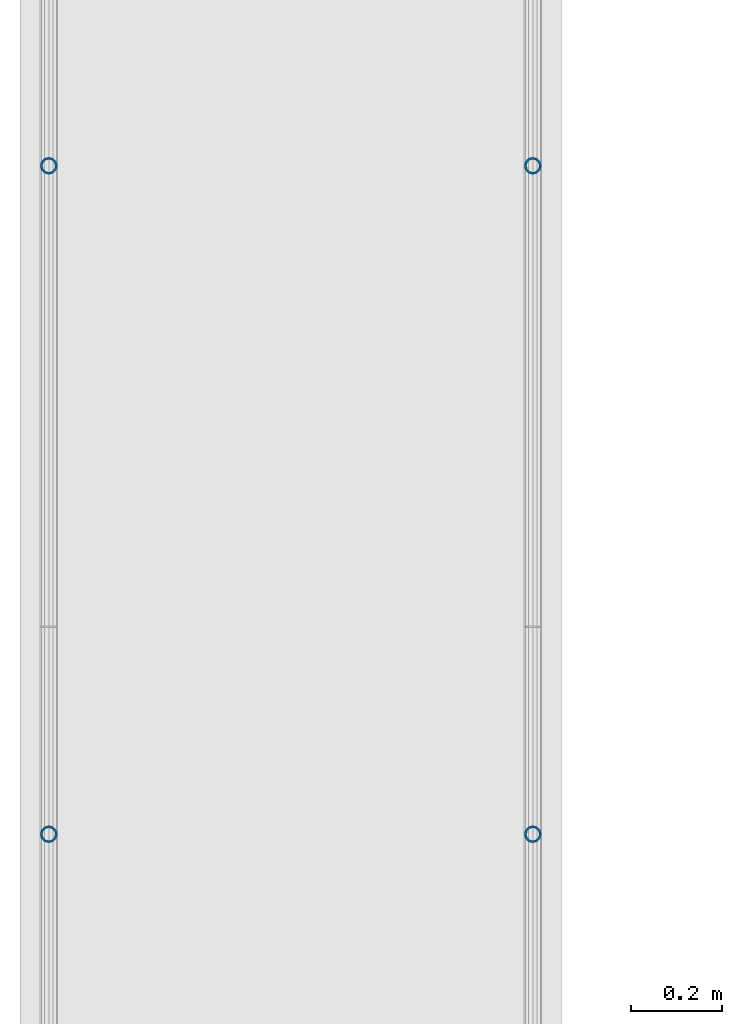
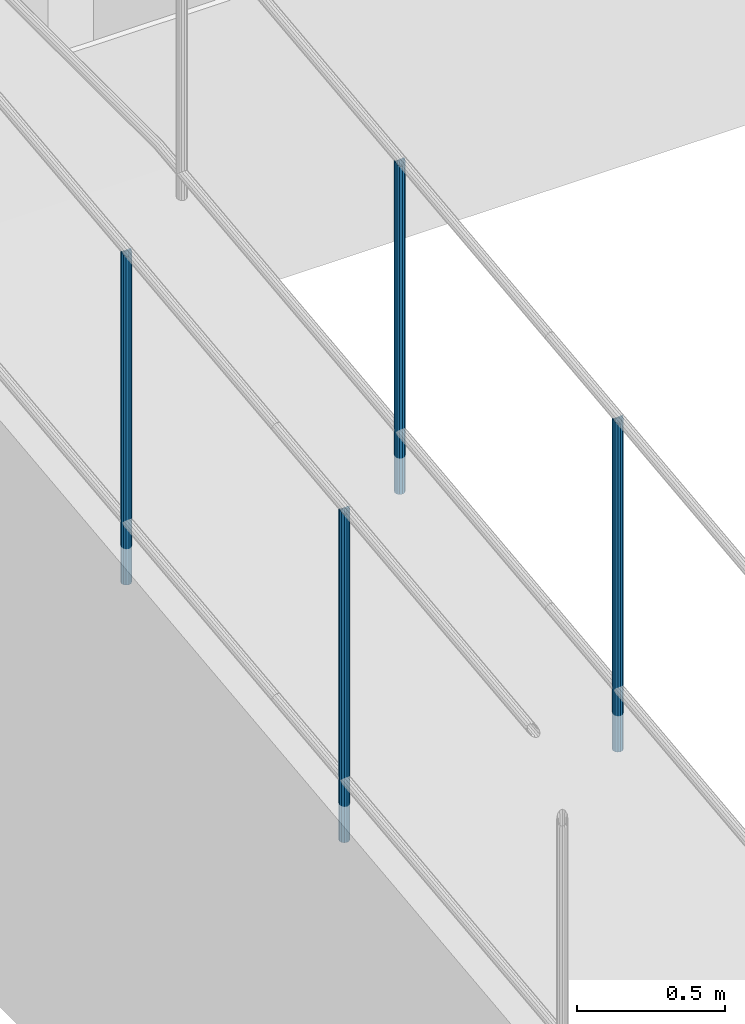
# One storey, part 882 of 1763: 4 columns, 4 elements without a shape of their own.
"""IFC2X3 building model written with IfcOpenShell, lengths in millimetres."""

from ifc_helpers import new_model, si_unit, frame, origin_with_axes, place, context, subcontext, project, spatial, faceted_brep, material, type_object, element, aggregate, save


model = new_model("IFC2X3")

# Units and contexts
model_context = context("Model", 3, precision=1e-05, world=origin_with_axes())
body_context = subcontext(model_context, "Body", "Model", "MODEL_VIEW")
ifc_project = project(units=[si_unit("LENGTHUNIT", "METRE", prefix="MILLI"), si_unit("AREAUNIT", "SQUARE_METRE"), si_unit("VOLUMEUNIT", "CUBIC_METRE"), si_unit("MASSUNIT", "GRAM", prefix="KILO"), si_unit("TIMEUNIT", "SECOND"), si_unit("PLANEANGLEUNIT", "RADIAN"), si_unit("SOLIDANGLEUNIT", "STERADIAN"), si_unit("THERMODYNAMICTEMPERATUREUNIT", "DEGREE_CELSIUS"), si_unit("LUMINOUSINTENSITYUNIT", "LUMEN")], contexts=[model_context])

# Site, building, storey
site_placement = place(None, origin_with_axes())
site = spatial("IfcSite", under=ifc_project, at=site_placement, CompositionType="ELEMENT")
building_placement = place(site_placement, origin_with_axes())
building = spatial("IfcBuilding", under=site, at=building_placement, Name="Undefined", CompositionType="ELEMENT")
storey_placement = place(building_placement, origin_with_axes())
storey = spatial("IfcBuildingStorey", under=building, at=storey_placement, Name="Undefined", CompositionType="ELEMENT", Elevation=0.0)

# Assembly, column
assembly_1_placement = place(storey_placement, origin_with_axes())
assembly_1 = element("IfcElementAssembly", 1, at=assembly_1_placement, inside=storey, Name="GUARDRAIL", AssemblyPlace="NOTDEFINED", PredefinedType="RIGID_FRAME")
ifc_material = material(Name="STEEL/A513")
column_type = type_object("IfcColumnType", PredefinedType="NOTDEFINED")
column_1_placement = place(assembly_1_placement, frame((-97200.6527017878, 3422.43745820545, 5422.13495796686), z_axis=(0.0, -0.999999999989044, 4.68099999989136e-06), x_axis=(0.0, 4.68100000009712e-06, 0.999999999989044)))
column_1 = element("IfcColumn", 2, at=column_1_placement, type_object=column_type, material=ifc_material, Name="POST TUBE", context=body_context, shape_type="Brep", body=[
    faceted_brep([(1371.60074802696, 19.0500000000029, -4.95674612466246e-10), (1360.91954353543, 16.4977839420899, 9.52499999992688), (1363.1068023618, 16.4977839420899, -9.52500000007285), (1352.93166657158, -7.14375000000291, 12.3733379564974), (1350.78515091293, 0.0, 14.2874999999276), (1350.23833620634, 0.0, 19.0499999999279), (1353.10035708436, -9.52499999999418, 16.4977839420208), (1353.84731986472, -9.52499999997963, 9.99208795651202), (1353.84731986473, 9.52500000000873, 9.99208795648292), (1353.10035708436, 9.52499999999418, 16.4977839420208), (1352.93166657157, 7.14375000000291, 12.3733379564974), (1357.04140787087, 12.3733379565674, 7.14374999992697), (1359.7883677507, 14.2875000000058, -7.27595761418343e-11), (1358.68185199063, 12.3733379565674, -7.14375000007294), (1356.14183772056, 9.52500000000873, -9.99208795662844), (1356.88880050093, 9.52499999999418, -16.4977839421663), (1355.77299913398, 7.14375000000291, -12.3733379566434), (1354.06603915248, 0.0, -14.2875000000727), (1354.61285385908, 0.0, -19.0500000000725), (1355.77299913399, -7.14375000000291, -12.3733379566434), (1356.14183772056, -9.52499999997963, -9.992087956658), (1356.88880050093, -9.52499999999418, -16.4977839421663), (1371.60075086449, -19.0499999999884, 1.21417542686686e-10), (1363.1068023618, -16.4977839420899, -9.52500000007285), (1360.91954353543, -16.4977839420899, 9.52499999992688), (1358.68185199066, -12.3733379565674, -7.14375000007294), (1359.78836775073, -14.2875000000058, -7.27595761418343e-11), (1357.0414078709, -12.3733379565674, 7.14374999992697), (0.0, -16.4977839420899, -9.52500000000146), (0.0, -9.52499999999418, -16.4977839420935), (1.45519152283669e-11, 1.81898940354586e-12, -19.0499999999993), (0.0, 9.52499999999418, -16.4977839420935), (0.0, 16.4977839420899, -9.52500000000146), (0.0, 19.0500000000029, 0.0), (0.0, 16.4977839420899, 9.52500000000146), (0.0, 9.52499999999418, 16.4977839420935), (1.45519152283669e-11, 1.81898940354586e-12, 19.0499999999993), (0.0, -9.52499999999418, 16.4977839420935), (0.0, -16.4977839420899, 9.52500000000146), (0.0, -19.0500000000029, 0.0), (0.0, -12.3733379565674, -7.14374999999927), (0.0, -7.14375000000291, -12.373337956571), (0.0, 0.0, -14.2874999999985), (0.0, 7.14375000000291, -12.373337956571), (0.0, 12.3733379565674, -7.14374999999927), (0.0, 14.2875000000058, 0.0), (0.0, 12.3733379565674, 7.14374999999927), (0.0, 7.14375000000291, 12.373337956571), (0.0, 0.0, 14.2874999999985), (0.0, -7.14375000000291, 12.373337956571), (0.0, -12.3733379565674, 7.14374999999927), (0.0, -14.2875000000058, 0.0)], [[[0, 1, 2]], [[3, 4, 5, 6, 7]], [[8, 9, 5, 4, 10]], [[2, 1, 9, 8, 11, 12, 13, 14, 15]], [[15, 14, 16, 17, 18]], [[18, 17, 19, 20, 21]], [[22, 23, 24]], [[21, 20, 25, 26, 27, 7, 6, 24, 23]], [[28, 29, 21, 23]], [[29, 30, 18, 21]], [[30, 31, 15, 18]], [[31, 32, 2, 15]], [[32, 33, 0, 2]], [[33, 34, 1, 0]], [[34, 35, 9, 1]], [[35, 36, 5, 9]], [[36, 37, 6, 5]], [[37, 38, 24, 6]], [[38, 39, 22, 24]], [[39, 28, 23, 22]], [[38, 37, 36, 35, 34, 33, 32, 31, 30, 29, 28, 39], [40, 41, 42, 43, 44, 45, 46, 47, 48, 49, 50, 51]], [[40, 51, 26, 25]], [[19, 41, 40, 25, 20]], [[42, 41, 19, 17]], [[43, 42, 17, 16]], [[44, 43, 16, 14, 13]], [[45, 44, 13, 12]], [[46, 45, 12, 11]], [[10, 47, 46, 11, 8]], [[48, 47, 10, 4]], [[49, 48, 4, 3]], [[50, 49, 3, 7, 27]], [[51, 50, 27, 26]]]),
])
aggregate(assembly_1, [column_1])

assembly_2_placement = place(storey_placement, origin_with_axes())
assembly_2 = element("IfcElementAssembly", 3, at=assembly_2_placement, inside=storey, Name="GUARDRAIL", AssemblyPlace="NOTDEFINED", PredefinedType="RIGID_FRAME")
column_2_placement = place(assembly_2_placement, frame((-97200.6527017878, 4895.63732340415, 5591.27584158143), z_axis=(0.0, -0.999999999989044, 4.68099999989136e-06), x_axis=(0.0, 4.68100000009712e-06, 0.999999999989044)))
column_2 = element("IfcColumn", 4, at=column_2_placement, type_object=column_type, material=ifc_material, Name="POST TUBE", context=body_context, shape_type="Brep", body=[
    faceted_brep([(1371.60074802696, 19.0500000000029, -4.95674612466246e-10), (1360.92004811796, 16.4977839420899, 9.52499999950942), (1363.10730659688, 16.4977839420899, -9.52500000049167), (1352.93217122176, -7.14375000000291, 12.3733379560817), (1350.78565560214, 0.0, 14.2874999995129), (1350.23884098241, 0.0, 19.0499999995127), (1353.10086180857, -9.52499999999418, 16.4977839416069), (1353.84782447028, -9.52499999999418, 9.99208795608138), (1353.84782447028, 9.52499999999418, 9.99208795608138), (1353.10086180857, 9.52499999999418, 16.4977839416069), (1352.93217122176, 7.14375000000291, 12.3733379560817), (1357.04191241844, 12.3733379565674, 7.14374999951087), (1359.78887216401, 14.2875000000058, -4.91127138957381e-10), (1358.68235627764, 12.3733379565674, -7.14375000048949), (1356.14234196164, 9.52499999999418, -9.99208795705908), (1356.88930462336, 9.52499999999418, -16.4977839425837), (1355.77350333285, 7.14375000000291, -12.3733379570585), (1354.06654332053, 0.0, -14.2875000004888), (1354.61335794026, 0.0, -19.0500000004886), (1355.77350333285, -7.14375000000291, -12.3733379570585), (1356.14234196164, -9.52499999999418, -9.99208795705908), (1356.88930462336, -9.52499999999418, -16.4977839425837), (1371.6012486538, -19.0500000000029, 5.74798359593842e-05), (1363.10730659688, -16.4977839420899, -9.52500000049167), (1360.92004811796, -16.4977839420899, 9.52499999950942), (1358.68235627763, -12.3733379565674, -7.14375000048949), (1359.788872164, -14.2875000000058, -4.91127138957381e-10), (1357.04191241844, -12.3733379565674, 7.14374999951087), (0.0, -16.4977839420899, -9.52500000000146), (0.0, -9.52499999999418, -16.4977839420935), (1.45519152283669e-11, 1.81898940354586e-12, -19.0499999999993), (0.0, 9.52499999999418, -16.4977839420935), (0.0, 16.4977839420899, -9.52500000000146), (0.0, 19.0500000000029, 0.0), (0.0, 16.4977839420899, 9.52500000000146), (0.0, 9.52499999999418, 16.4977839420935), (1.45519152283669e-11, 1.81898940354586e-12, 19.0499999999993), (0.0, -9.52499999999418, 16.4977839420935), (0.0, -16.4977839420899, 9.52500000000146), (0.0, -19.0500000000029, 0.0), (0.0, -12.3733379565674, -7.14374999999927), (0.0, -7.14375000000291, -12.373337956571), (0.0, 0.0, -14.2874999999985), (0.0, 7.14375000000291, -12.373337956571), (0.0, 12.3733379565674, -7.14374999999927), (0.0, 14.2875000000058, 0.0), (0.0, 12.3733379565674, 7.14374999999927), (0.0, 7.14375000000291, 12.373337956571), (0.0, 0.0, 14.2874999999985), (0.0, -7.14375000000291, 12.373337956571), (0.0, -12.3733379565674, 7.14374999999927), (0.0, -14.2875000000058, 0.0)], [[[0, 1, 2]], [[3, 4, 5, 6, 7]], [[8, 9, 5, 4, 10]], [[2, 1, 9, 8, 11, 12, 13, 14, 15]], [[15, 14, 16, 17, 18]], [[18, 17, 19, 20, 21]], [[22, 23, 24]], [[21, 20, 25, 26, 27, 7, 6, 24, 23]], [[28, 29, 21, 23]], [[29, 30, 18, 21]], [[30, 31, 15, 18]], [[31, 32, 2, 15]], [[32, 33, 0, 2]], [[33, 34, 1, 0]], [[34, 35, 9, 1]], [[35, 36, 5, 9]], [[36, 37, 6, 5]], [[37, 38, 24, 6]], [[38, 39, 22, 24]], [[39, 28, 23, 22]], [[38, 37, 36, 35, 34, 33, 32, 31, 30, 29, 28, 39], [40, 41, 42, 43, 44, 45, 46, 47, 48, 49, 50, 51]], [[40, 51, 26, 25]], [[19, 41, 40, 25, 20]], [[42, 41, 19, 17]], [[43, 42, 17, 16]], [[44, 43, 16, 14, 13]], [[45, 44, 13, 12]], [[46, 45, 12, 11]], [[10, 47, 46, 11, 8]], [[48, 47, 10, 4]], [[49, 48, 4, 3]], [[50, 49, 3, 7, 27]], [[51, 50, 27, 26]]]),
])
aggregate(assembly_2, [column_2])

assembly_3_placement = place(storey_placement, origin_with_axes())
assembly_3 = element("IfcElementAssembly", 5, at=assembly_3_placement, inside=storey, Name="GUARDRAIL", AssemblyPlace="NOTDEFINED", PredefinedType="RIGID_FRAME")
column_3_placement = place(assembly_3_placement, frame((-96133.8527017878, 4895.63732340415, 5591.27584158143), z_axis=(0.0, -0.999999999989044, 4.68099999989136e-06), x_axis=(0.0, 4.68100000009712e-06, 0.999999999989044)))
column_3 = element("IfcColumn", 6, at=column_3_placement, type_object=column_type, material=ifc_material, Name="POST TUBE", context=body_context, shape_type="Brep", body=[
    faceted_brep([(1371.60074802696, 19.0500000000029, -4.95674612466246e-10), (1360.92004811796, 16.4977839420899, 9.52499999950942), (1363.10730659688, 16.4977839420899, -9.52500000049167), (1352.93217122176, -7.14375000000291, 12.3733379560817), (1350.78565560214, 0.0, 14.2874999995129), (1350.23884098241, 0.0, 19.0499999995127), (1353.10086180857, -9.52499999999418, 16.4977839416069), (1353.84782447028, -9.52499999999418, 9.99208795608138), (1353.84782447028, 9.52499999999418, 9.99208795608138), (1353.10086180857, 9.52499999999418, 16.4977839416069), (1352.93217122176, 7.14375000000291, 12.3733379560817), (1357.04191241844, 12.3733379565674, 7.14374999951087), (1359.78887216401, 14.2875000000058, -4.91127138957381e-10), (1358.68235627764, 12.3733379565674, -7.14375000048949), (1356.14234196164, 9.52499999999418, -9.99208795705908), (1356.88930462336, 9.52499999999418, -16.4977839425837), (1355.77350333285, 7.14375000000291, -12.3733379570585), (1354.06654332053, 0.0, -14.2875000004888), (1354.61335794026, 0.0, -19.0500000004886), (1355.77350333285, -7.14375000000291, -12.3733379570585), (1356.14234196164, -9.52499999999418, -9.99208795705908), (1356.88930462336, -9.52499999999418, -16.4977839425837), (1371.6012486538, -19.0500000000029, 5.74798359593842e-05), (1363.10730659688, -16.4977839420899, -9.52500000049167), (1360.92004811796, -16.4977839420899, 9.52499999950942), (1358.68235627763, -12.3733379565674, -7.14375000048949), (1359.788872164, -14.2875000000058, -4.91127138957381e-10), (1357.04191241844, -12.3733379565674, 7.14374999951087), (0.0, -16.4977839420899, -9.52500000000146), (0.0, -9.52499999999418, -16.4977839420935), (1.45519152283669e-11, 1.81898940354586e-12, -19.0499999999993), (0.0, 9.52499999999418, -16.4977839420935), (0.0, 16.4977839420899, -9.52500000000146), (0.0, 19.0500000000029, 0.0), (0.0, 16.4977839420899, 9.52500000000146), (0.0, 9.52499999999418, 16.4977839420935), (1.45519152283669e-11, 1.81898940354586e-12, 19.0499999999993), (0.0, -9.52499999999418, 16.4977839420935), (0.0, -16.4977839420899, 9.52500000000146), (0.0, -19.0500000000029, 0.0), (0.0, -12.3733379565674, -7.14374999999927), (0.0, -7.14375000000291, -12.373337956571), (0.0, 0.0, -14.2874999999985), (0.0, 7.14375000000291, -12.373337956571), (0.0, 12.3733379565674, -7.14374999999927), (0.0, 14.2875000000058, 0.0), (0.0, 12.3733379565674, 7.14374999999927), (0.0, 7.14375000000291, 12.373337956571), (0.0, 0.0, 14.2874999999985), (0.0, -7.14375000000291, 12.373337956571), (0.0, -12.3733379565674, 7.14374999999927), (0.0, -14.2875000000058, 0.0)], [[[0, 1, 2]], [[3, 4, 5, 6, 7]], [[8, 9, 5, 4, 10]], [[2, 1, 9, 8, 11, 12, 13, 14, 15]], [[15, 14, 16, 17, 18]], [[18, 17, 19, 20, 21]], [[22, 23, 24]], [[21, 20, 25, 26, 27, 7, 6, 24, 23]], [[28, 29, 21, 23]], [[29, 30, 18, 21]], [[30, 31, 15, 18]], [[31, 32, 2, 15]], [[32, 33, 0, 2]], [[33, 34, 1, 0]], [[34, 35, 9, 1]], [[35, 36, 5, 9]], [[36, 37, 6, 5]], [[37, 38, 24, 6]], [[38, 39, 22, 24]], [[39, 28, 23, 22]], [[38, 37, 36, 35, 34, 33, 32, 31, 30, 29, 28, 39], [40, 41, 42, 43, 44, 45, 46, 47, 48, 49, 50, 51]], [[40, 51, 26, 25]], [[19, 41, 40, 25, 20]], [[42, 41, 19, 17]], [[43, 42, 17, 16]], [[44, 43, 16, 14, 13]], [[45, 44, 13, 12]], [[46, 45, 12, 11]], [[10, 47, 46, 11, 8]], [[48, 47, 10, 4]], [[49, 48, 4, 3]], [[50, 49, 3, 7, 27]], [[51, 50, 27, 26]]]),
])
aggregate(assembly_3, [column_3])

assembly_4_placement = place(storey_placement, origin_with_axes())
assembly_4 = element("IfcElementAssembly", 7, at=assembly_4_placement, inside=storey, Name="GUARDRAIL", AssemblyPlace="NOTDEFINED", PredefinedType="RIGID_FRAME")
column_4_placement = place(assembly_4_placement, frame((-96133.8527017878, 3422.43745820545, 5422.13495796686), z_axis=(0.0, -0.999999999989044, 4.68099999989136e-06), x_axis=(0.0, 4.68100000009712e-06, 0.999999999989044)))
column_4 = element("IfcColumn", 8, at=column_4_placement, type_object=column_type, material=ifc_material, Name="POST TUBE", context=body_context, shape_type="Brep", body=[
    faceted_brep([(1371.60074802696, 19.0500000000029, -4.95674612466246e-10), (1360.91954353543, 16.4977839420899, 9.52499999992688), (1363.1068023618, 16.4977839420899, -9.52500000007285), (1352.93166657158, -7.14375000000291, 12.3733379564974), (1350.78515091293, 0.0, 14.2874999999276), (1350.23833620634, 0.0, 19.0499999999279), (1353.10035708436, -9.52499999999418, 16.4977839420208), (1353.84731986472, -9.52499999997963, 9.99208795651202), (1353.84731986473, 9.52500000000873, 9.99208795648292), (1353.10035708436, 9.52499999999418, 16.4977839420208), (1352.93166657157, 7.14375000000291, 12.3733379564974), (1357.04140787087, 12.3733379565674, 7.14374999992697), (1359.7883677507, 14.2875000000058, -7.27595761418343e-11), (1358.68185199063, 12.3733379565674, -7.14375000007294), (1356.14183772056, 9.52500000000873, -9.99208795662844), (1356.88880050093, 9.52499999999418, -16.4977839421663), (1355.77299913398, 7.14375000000291, -12.3733379566434), (1354.06603915248, 0.0, -14.2875000000727), (1354.61285385908, 0.0, -19.0500000000725), (1355.77299913399, -7.14375000000291, -12.3733379566434), (1356.14183772056, -9.52499999997963, -9.992087956658), (1356.88880050093, -9.52499999999418, -16.4977839421663), (1371.60075086449, -19.0499999999884, 1.21417542686686e-10), (1363.1068023618, -16.4977839420899, -9.52500000007285), (1360.91954353543, -16.4977839420899, 9.52499999992688), (1358.68185199066, -12.3733379565674, -7.14375000007294), (1359.78836775073, -14.2875000000058, -7.27595761418343e-11), (1357.0414078709, -12.3733379565674, 7.14374999992697), (0.0, -16.4977839420899, -9.52500000000146), (0.0, -9.52499999999418, -16.4977839420935), (1.45519152283669e-11, 1.81898940354586e-12, -19.0499999999993), (0.0, 9.52499999999418, -16.4977839420935), (0.0, 16.4977839420899, -9.52500000000146), (0.0, 19.0500000000029, 0.0), (0.0, 16.4977839420899, 9.52500000000146), (0.0, 9.52499999999418, 16.4977839420935), (1.45519152283669e-11, 1.81898940354586e-12, 19.0499999999993), (0.0, -9.52499999999418, 16.4977839420935), (0.0, -16.4977839420899, 9.52500000000146), (0.0, -19.0500000000029, 0.0), (0.0, -12.3733379565674, -7.14374999999927), (0.0, -7.14375000000291, -12.373337956571), (0.0, 0.0, -14.2874999999985), (0.0, 7.14375000000291, -12.373337956571), (0.0, 12.3733379565674, -7.14374999999927), (0.0, 14.2875000000058, 0.0), (0.0, 12.3733379565674, 7.14374999999927), (0.0, 7.14375000000291, 12.373337956571), (0.0, 0.0, 14.2874999999985), (0.0, -7.14375000000291, 12.373337956571), (0.0, -12.3733379565674, 7.14374999999927), (0.0, -14.2875000000058, 0.0)], [[[0, 1, 2]], [[3, 4, 5, 6, 7]], [[8, 9, 5, 4, 10]], [[2, 1, 9, 8, 11, 12, 13, 14, 15]], [[15, 14, 16, 17, 18]], [[18, 17, 19, 20, 21]], [[22, 23, 24]], [[21, 20, 25, 26, 27, 7, 6, 24, 23]], [[28, 29, 21, 23]], [[29, 30, 18, 21]], [[30, 31, 15, 18]], [[31, 32, 2, 15]], [[32, 33, 0, 2]], [[33, 34, 1, 0]], [[34, 35, 9, 1]], [[35, 36, 5, 9]], [[36, 37, 6, 5]], [[37, 38, 24, 6]], [[38, 39, 22, 24]], [[39, 28, 23, 22]], [[38, 37, 36, 35, 34, 33, 32, 31, 30, 29, 28, 39], [40, 41, 42, 43, 44, 45, 46, 47, 48, 49, 50, 51]], [[40, 51, 26, 25]], [[19, 41, 40, 25, 20]], [[42, 41, 19, 17]], [[43, 42, 17, 16]], [[44, 43, 16, 14, 13]], [[45, 44, 13, 12]], [[46, 45, 12, 11]], [[10, 47, 46, 11, 8]], [[48, 47, 10, 4]], [[49, 48, 4, 3]], [[50, 49, 3, 7, 27]], [[51, 50, 27, 26]]]),
])
aggregate(assembly_4, [column_4])

save(model, "model.ifc")
